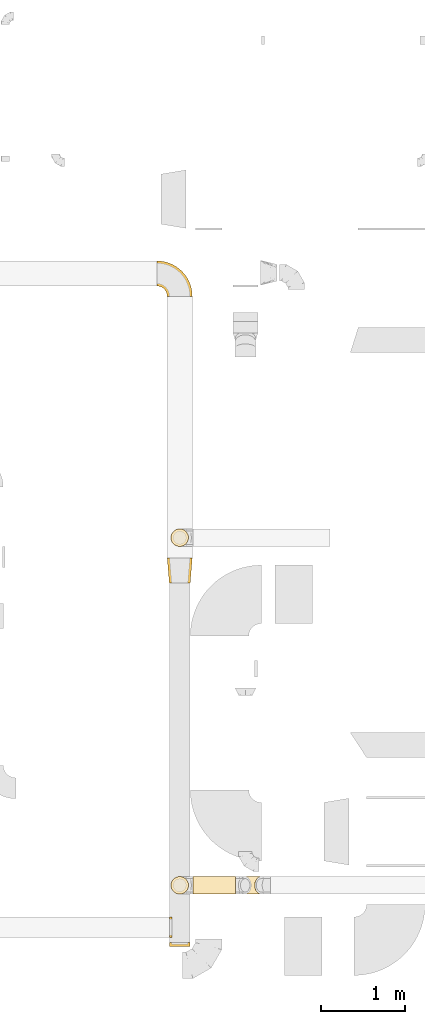
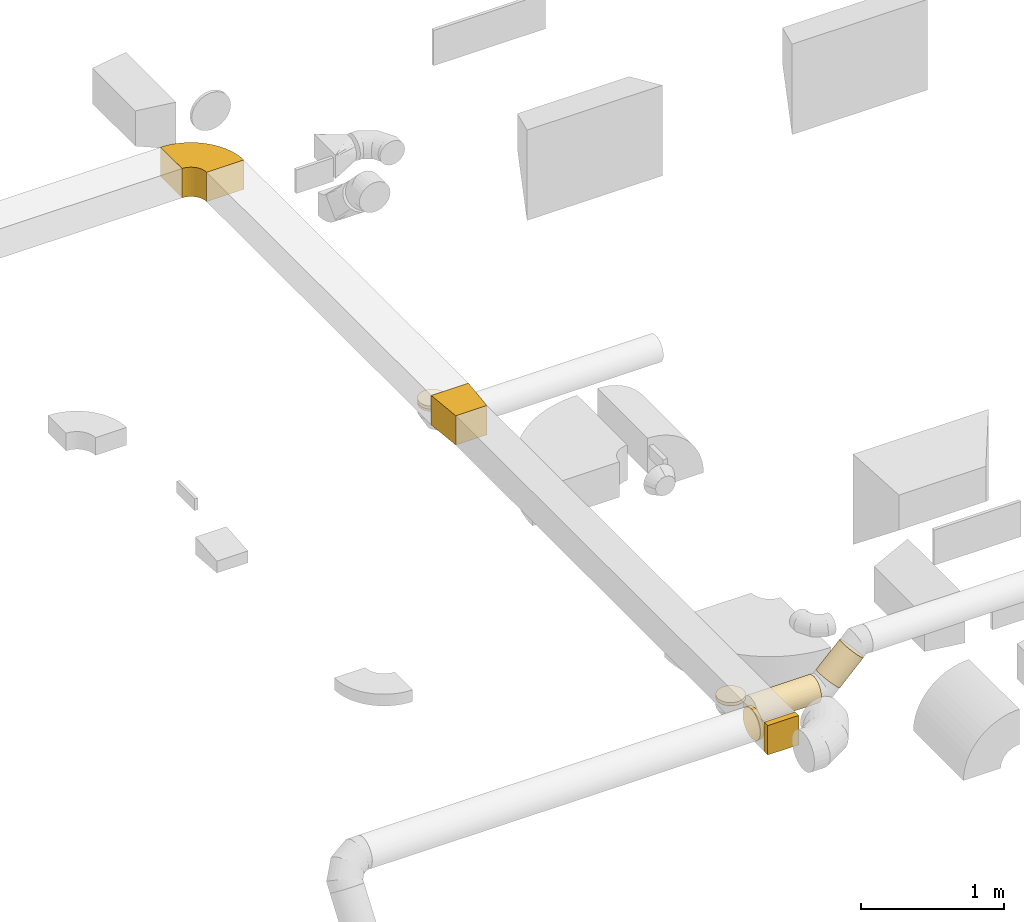
# One storey, part 5 of 62: 10 coverings.
"""IFC2X3 building model written with IfcOpenShell, lengths in millimetres."""

from ifc_helpers import new_model, entity, si_unit, converted_unit, derived_unit, direction, frame, frame_2d, origin, origin_2d_with_axis, place, context, subcontext, project, spatial, polyline, circle_curve, parameter, trimmed, segment, composite_curve, rectangle, circle, outline, extrude, element, save


model = new_model("IFC2X3")

# Units and contexts
model_context = context("Model", 3, precision=0.01, world=origin(), true_north=direction((6.12303176911189e-17, 1.0)))
body_context = subcontext(model_context, "Body", "Model", "MODEL_VIEW")
ifc_project = project(units=[si_unit("LENGTHUNIT", "METRE", prefix="MILLI"), si_unit("AREAUNIT", "SQUARE_METRE"), si_unit("VOLUMEUNIT", "CUBIC_METRE"), converted_unit("PLANEANGLEUNIT", "DEGREE", entity("IfcRatioMeasure", 0.0174532925199433), si_unit("PLANEANGLEUNIT", "RADIAN"), dimensions=[0, 0, 0, 0, 0, 0, 0]), si_unit("MASSUNIT", "GRAM", prefix="KILO"), derived_unit("MASSDENSITYUNIT", [(si_unit("MASSUNIT", "GRAM", prefix="KILO"), 1), (si_unit("LENGTHUNIT", "METRE"), -3)]), derived_unit("MOMENTOFINERTIAUNIT", [(si_unit("LENGTHUNIT", "METRE"), 4)]), si_unit("TIMEUNIT", "SECOND"), si_unit("FREQUENCYUNIT", "HERTZ"), si_unit("THERMODYNAMICTEMPERATUREUNIT", "DEGREE_CELSIUS"), derived_unit("THERMALTRANSMITTANCEUNIT", [(si_unit("MASSUNIT", "GRAM", prefix="KILO"), 1), (si_unit("THERMODYNAMICTEMPERATUREUNIT", "KELVIN"), -1), (si_unit("TIMEUNIT", "SECOND"), -3)]), derived_unit("VOLUMETRICFLOWRATEUNIT", [(si_unit("LENGTHUNIT", "METRE"), 3), (si_unit("TIMEUNIT", "SECOND"), -1)]), derived_unit("MASSFLOWRATEUNIT", [(si_unit("MASSUNIT", "GRAM", prefix="KILO"), 1), (si_unit("TIMEUNIT", "SECOND"), -1)]), derived_unit("ROTATIONALFREQUENCYUNIT", [(si_unit("TIMEUNIT", "SECOND"), -1)]), si_unit("ELECTRICCURRENTUNIT", "AMPERE"), si_unit("ELECTRICVOLTAGEUNIT", "VOLT"), si_unit("POWERUNIT", "WATT"), si_unit("FORCEUNIT", "NEWTON", prefix="KILO"), si_unit("ILLUMINANCEUNIT", "LUX"), si_unit("LUMINOUSFLUXUNIT", "LUMEN"), si_unit("LUMINOUSINTENSITYUNIT", "CANDELA"), derived_unit("USERDEFINED", [(si_unit("MASSUNIT", "GRAM", prefix="KILO"), -1), (si_unit("LENGTHUNIT", "METRE"), -2), (si_unit("TIMEUNIT", "SECOND"), 3), (si_unit("LUMINOUSFLUXUNIT", "LUMEN"), 1)]), derived_unit("LINEARVELOCITYUNIT", [(si_unit("LENGTHUNIT", "METRE"), 1), (si_unit("TIMEUNIT", "SECOND"), -1)]), si_unit("PRESSUREUNIT", "PASCAL"), derived_unit("USERDEFINED", [(si_unit("LENGTHUNIT", "METRE"), -2), (si_unit("MASSUNIT", "GRAM", prefix="KILO"), 1), (si_unit("TIMEUNIT", "SECOND"), -2)]), derived_unit("LINEARFORCEUNIT", [(si_unit("MASSUNIT", "GRAM", prefix="KILO"), 1), (si_unit("LENGTHUNIT", "METRE"), 1), (si_unit("TIMEUNIT", "SECOND"), -2), (si_unit("LENGTHUNIT", "METRE"), -1)]), derived_unit("PLANARFORCEUNIT", [(si_unit("MASSUNIT", "GRAM", prefix="KILO"), 1), (si_unit("LENGTHUNIT", "METRE"), 1), (si_unit("TIMEUNIT", "SECOND"), -2), (si_unit("LENGTHUNIT", "METRE"), -2)])], contexts=[model_context])

# Site, building, storey
site_placement = place(None, origin())
site = spatial("IfcSite", under=ifc_project, at=site_placement, CompositionType="ELEMENT")
building_placement = place(site_placement, origin())
building = spatial("IfcBuilding", under=site, at=building_placement, CompositionType="ELEMENT")
storey_placement = place(building_placement, frame((0.0, 0.0, 24000.0)))
storey = spatial("IfcBuildingStorey", under=building, at=storey_placement, CompositionType="ELEMENT", Elevation=24000.0)

# Coverings
covering_1_placement = place(storey_placement, frame((67566.73, 5168.12, 3475.0)))
element("IfcCovering", 1, at=covering_1_placement, inside=storey, PredefinedType="INSULATION", context=body_context, shape_type="SweptSolid", body=[
    extrude(outline(polyline([(-161.94, -137.03), (139.1, -137.03), (159.86, 112.11), (-137.03, 161.94), (-161.94, -137.03)])), frame((150.0, 150.0, 0.0), z_axis=(0.0, 0.0, 1.0), x_axis=(0.0830454798535212, -0.996545758244898, 0.0)), (0.0, 0.0, 1.0), 250.000000000004),
])
covering_2_placement = place(storey_placement, frame((67610.13, 5604.78, 3460.0)))
element("IfcCovering", 2, at=covering_2_placement, inside=storey, PredefinedType="INSULATION", context=body_context, shape_type="SweptSolid", body=[
    extrude(circle(Radius=105.0, at=origin_2d_with_axis()), frame((106.6, 106.6, 0.0), z_axis=(0.0, 0.0, 1.0), x_axis=(0.0, 1.0, 0.0)), (0.0, 0.0, 1.0), 19.9999999999738),
])
covering_3_placement = place(storey_placement, frame((67610.13, 5604.78, 3480.0)))
element("IfcCovering", 3, at=covering_3_placement, inside=storey, PredefinedType="INSULATION", context=body_context, shape_type="SweptSolid", body=[
    extrude(circle(Radius=105.0, at=origin_2d_with_axis()), frame((106.6, 106.6, 0.0), z_axis=(0.0, 0.0, 1.0), x_axis=(0.0, 1.0, 0.0)), (0.0, 0.0, 1.0), 26.0960000000419),
])
covering_4_placement = place(storey_placement, frame((68424.35, 1444.8, 3287.62)))
element("IfcCovering", 4, at=covering_4_placement, inside=storey, PredefinedType="INSULATION", context=body_context, shape_type="SweptSolid", body=[
    extrude(circle(Radius=105.0, at=origin_2d_with_axis()), frame((75.84, 106.6, 75.84), z_axis=(0.707106781186555, 0.0, 0.707106781186541), x_axis=(0.0, -1.0, 0.0)), (0.0, 0.0, 1.0), 268.248557872836),
])
covering_5_placement = place(storey_placement, frame((67876.73, 1444.8, 3210.0)))
element("IfcCovering", 5, at=covering_5_placement, inside=storey, PredefinedType="INSULATION", context=body_context, shape_type="SweptSolid", body=[
    extrude(circle(Radius=105.0, at=origin_2d_with_axis()), frame((0.0, 106.6, 106.6), z_axis=(1.0, 0.0, 0.0), x_axis=(0.0, -1.0, 0.0)), (0.0, 0.0, 1.0), 510.319625684626),
])
covering_6_placement = place(storey_placement, frame((67610.13, 1444.8, 3476.59)))
element("IfcCovering", 6, at=covering_6_placement, inside=storey, PredefinedType="INSULATION", context=body_context, shape_type="SweptSolid", body=[
    extrude(circle(Radius=105.0, at=origin_2d_with_axis()), frame((106.6, 106.6, 0.0), z_axis=(0.0, 0.0, 1.0), x_axis=(0.0, 1.0, 0.0)), (0.0, 0.0, 1.0), 3.40620433568568),
])
covering_7_placement = place(storey_placement, frame((67610.13, 1444.8, 3480.0)))
element("IfcCovering", 7, at=covering_7_placement, inside=storey, PredefinedType="INSULATION", context=body_context, shape_type="SweptSolid", body=[
    extrude(circle(Radius=105.0, at=origin_2d_with_axis()), frame((106.6, 106.6, 0.0), z_axis=(0.0, 0.0, 1.0), x_axis=(0.0, 1.0, 0.0)), (0.0, 0.0, 1.0), 26.0960000000419),
])
covering_8_placement = place(storey_placement, frame((67596.73, 923.29, 3473.4)))
element("IfcCovering", 8, at=covering_8_placement, inside=storey, PredefinedType="INSULATION", context=body_context, shape_type="SweptSolid", body=[
    extrude(circle(Radius=125.0, at=origin_2d_with_axis()), frame((0.0, 126.6, 126.6), z_axis=(1.0, 0.0, 0.0), x_axis=(0.0, -1.0, 0.0)), (0.0, 0.0, 1.0), 26.0960000000592),
])
covering_9_placement = place(storey_placement, frame((67591.73, 818.12, 3475.0)))
element("IfcCovering", 9, at=covering_9_placement, inside=storey, PredefinedType="INSULATION", context=body_context, shape_type="SweptSolid", body=[
    extrude(rectangle(XDim=50.0000000000005, YDim=250.000000000004, at=origin_2d_with_axis()), frame((125.0, 25.0, 0.0), z_axis=(0.0, 0.0, 1.0), x_axis=(0.0, 1.0, 0.0)), (0.0, 0.0, 1.0), 250.000000000004),
])
covering_10_placement = place(storey_placement, frame((67440.13, 8598.43, 3475.0)))
element("IfcCovering", 10, at=covering_10_placement, inside=storey, PredefinedType="INSULATION", context=body_context, shape_type="SweptSolid", body=[
    extrude(outline(composite_curve([segment(polyline([(-137.5, 12.5), (-137.5, -287.5)]), True, "CONTINUOUS"), segment(trimmed(circle_curve(frame_2d((-137.5, 137.5), x_axis=(1.0, 0.0)), 425.0), [parameter(270.0)], [parameter(0.0)], True, "PARAMETER"), True, "CONTINUOUS"), segment(polyline([(287.5, 137.5), (-12.5, 137.5)]), True, "CONTINUOUS"), segment(trimmed(circle_curve(frame_2d((-137.5, 137.5), x_axis=(1.0, 0.0)), 125.0), [parameter(270.0)], [parameter(360.0)], True, "PARAMETER"), False, "CONTINUOUS")], self_intersect=False)), frame((139.1, 139.1, 0.0), z_axis=(0.0, 0.0, -1.0), x_axis=(1.0, 0.0, 0.0)), (0.0, 0.0, -1.0), 250.000000000004),
])

save(model, "model.ifc")
